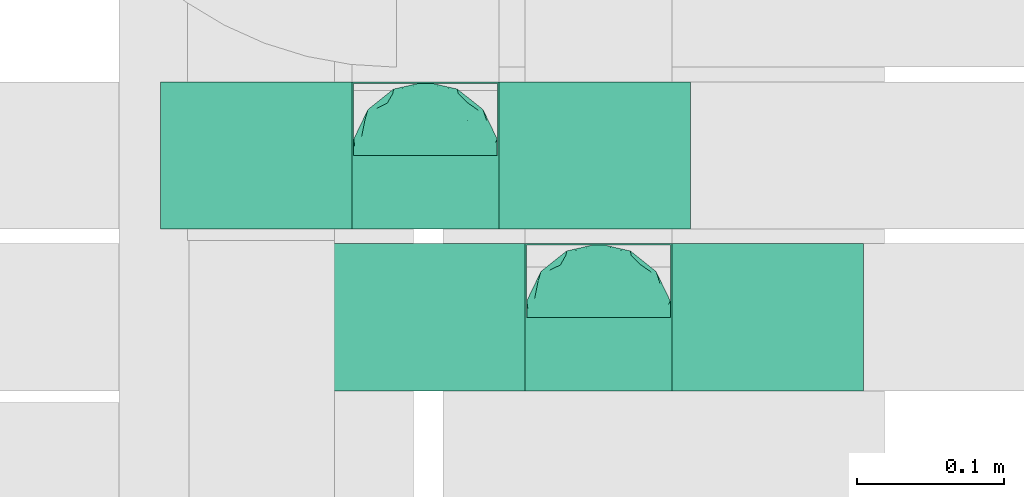
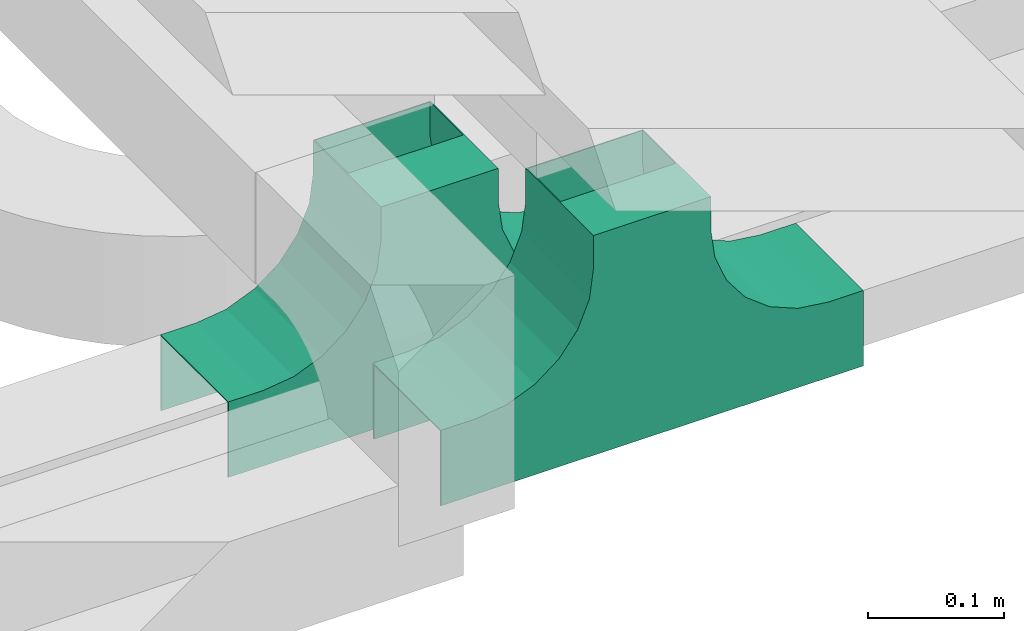
# One storey, part 15 of 19: 2 flow fittings.
"""IFC2X3 building model written with IfcOpenShell, lengths in millimetres."""

from ifc_helpers import new_model, entity, si_unit, converted_unit, derived_unit, direction, frame, origin, place, context, subcontext, project, spatial, faceted_brep, source, transform, mapped, material, material_list, type_object, type_shapes, element, save


model = new_model("IFC2X3")

# Units and contexts
model_context = context("Model", 3, precision=0.01, world=origin(), true_north=direction((6.12303176911189e-17, 1.0)))
body_context = subcontext(model_context, "Body", "Model", "MODEL_VIEW")
ifc_project = project(units=[si_unit("LENGTHUNIT", "METRE", prefix="MILLI"), si_unit("AREAUNIT", "SQUARE_METRE"), si_unit("VOLUMEUNIT", "CUBIC_METRE"), converted_unit("PLANEANGLEUNIT", "DEGREE", entity("IfcRatioMeasure", 0.0174532925199433), si_unit("PLANEANGLEUNIT", "RADIAN"), dimensions=[0, 0, 0, 0, 0, 0, 0]), si_unit("MASSUNIT", "GRAM", prefix="KILO"), derived_unit("MASSDENSITYUNIT", [(si_unit("MASSUNIT", "GRAM", prefix="KILO"), 1), (si_unit("LENGTHUNIT", "METRE"), -3)]), derived_unit("MOMENTOFINERTIAUNIT", [(si_unit("LENGTHUNIT", "METRE"), 4)]), si_unit("TIMEUNIT", "SECOND"), si_unit("FREQUENCYUNIT", "HERTZ"), si_unit("THERMODYNAMICTEMPERATUREUNIT", "DEGREE_CELSIUS"), derived_unit("THERMALTRANSMITTANCEUNIT", [(si_unit("MASSUNIT", "GRAM", prefix="KILO"), 1), (si_unit("THERMODYNAMICTEMPERATUREUNIT", "KELVIN"), -1), (si_unit("TIMEUNIT", "SECOND"), -3)]), derived_unit("VOLUMETRICFLOWRATEUNIT", [(si_unit("LENGTHUNIT", "METRE"), 3), (si_unit("TIMEUNIT", "SECOND"), -1)]), derived_unit("MASSFLOWRATEUNIT", [(si_unit("MASSUNIT", "GRAM", prefix="KILO"), 1), (si_unit("TIMEUNIT", "SECOND"), -1)]), derived_unit("ROTATIONALFREQUENCYUNIT", [(si_unit("TIMEUNIT", "SECOND"), -1)]), si_unit("ELECTRICCURRENTUNIT", "AMPERE"), si_unit("ELECTRICVOLTAGEUNIT", "VOLT"), si_unit("POWERUNIT", "WATT"), si_unit("FORCEUNIT", "NEWTON", prefix="KILO"), si_unit("ILLUMINANCEUNIT", "LUX"), si_unit("LUMINOUSFLUXUNIT", "LUMEN"), si_unit("LUMINOUSINTENSITYUNIT", "CANDELA"), derived_unit("USERDEFINED", [(si_unit("MASSUNIT", "GRAM", prefix="KILO"), -1), (si_unit("LENGTHUNIT", "METRE"), -2), (si_unit("TIMEUNIT", "SECOND"), 3), (si_unit("LUMINOUSFLUXUNIT", "LUMEN"), 1)]), derived_unit("LINEARVELOCITYUNIT", [(si_unit("LENGTHUNIT", "METRE"), 1), (si_unit("TIMEUNIT", "SECOND"), -1)]), si_unit("PRESSUREUNIT", "PASCAL"), derived_unit("USERDEFINED", [(si_unit("LENGTHUNIT", "METRE"), -2), (si_unit("MASSUNIT", "GRAM", prefix="KILO"), 1), (si_unit("TIMEUNIT", "SECOND"), -2)]), derived_unit("LINEARFORCEUNIT", [(si_unit("MASSUNIT", "GRAM", prefix="KILO"), 1), (si_unit("LENGTHUNIT", "METRE"), 1), (si_unit("TIMEUNIT", "SECOND"), -2), (si_unit("LENGTHUNIT", "METRE"), -1)]), derived_unit("PLANARFORCEUNIT", [(si_unit("MASSUNIT", "GRAM", prefix="KILO"), 1), (si_unit("LENGTHUNIT", "METRE"), 1), (si_unit("TIMEUNIT", "SECOND"), -2), (si_unit("LENGTHUNIT", "METRE"), -2)])], contexts=[model_context])

# Site, building, storey
site_placement = place(None, origin())
site = spatial("IfcSite", under=ifc_project, at=site_placement, CompositionType="ELEMENT")
building_placement = place(site_placement, origin())
building = spatial("IfcBuilding", under=site, at=building_placement, CompositionType="ELEMENT")
storey_placement = place(building_placement, frame((0.0, 0.0, 12000.0)))
storey = spatial("IfcBuildingStorey", under=building, at=storey_placement, CompositionType="ELEMENT", Elevation=12000.0)

# Flow fittings
ifc_material_1 = material()
ifc_material_2 = material()
ifc_material_list = material_list([ifc_material_1, ifc_material_2])
cable_carrier_fitting_type = type_object("IfcCableCarrierFittingType", Name="470_DKC_S5_TSS cover (flat)", PredefinedType="NOTDEFINED", material=ifc_material_1)
shared_shape = source(origin(), body_context, "Body", "Brep", [
    faceted_brep([(43.65, -13.62, 44.78), (44.77, 0.0, 42.74), (48.26, -5.6, 53.19), (16.66, 5.33, 18.16), (11.56, -8.33, 17.07), (2.02, 2.7, 15.11), (-7.81, -35.95, 31.14), (-17.21, -38.27, 37.81), (-11.13, -27.32, 24.63), (37.7, -7.25, 32.97), (10.64, 26.52, 23.97), (19.21, 19.84, 23.32), (10.42, 17.81, 19.46), (48.75, 0.0, 65.0), (48.07, 6.52, 52.87), (-37.46, 12.16, 34.19), (-31.35, 12.15, 27.99), (-38.09, 3.52, 32.8), (48.75, 11.13, 65.0), (9.67, 42.57, 40.61), (17.48, 37.97, 37.57), (8.35, 35.36, 30.65), (36.7, 20.43, 37.88), (28.22, 12.58, 25.69), (28.4, 24.01, 31.57), (37.1, 7.75, 32.39), (30.39, 38.11, 65.0), (34.74, 34.64, 65.0), (32.94, 32.13, 45.44), (26.04, 41.58, 65.0), (-44.77, 0.0, 42.74), (-35.92, -8.72, 31.33), (-42.7, -12.19, 42.01), (5.42, -48.76, 65.0), (0.0, -48.78, 54.04), (7.59, -47.43, 51.12), (34.0, -31.65, 46.49), (40.01, -26.24, 50.49), (30.39, -38.11, 65.0), (-47.55, -8.65, 52.2), (43.92, -21.15, 65.0), (-47.55, 8.68, 52.19), (-43.92, 21.15, 65.0), (-41.56, 23.54, 50.22), (-36.7, 20.43, 37.88), (-42.68, 12.16, 41.97), (-0.04, -44.68, 42.56), (43.35, 13.13, 43.81), (-9.67, -42.82, 41.06), (2.93, -38.3, 33.0), (10.58, -32.36, 28.38), (17.48, -37.97, 37.57), (29.42, -14.29, 27.18), (29.26, 0.0, 24.46), (-34.74, 34.64, 65.0), (-35.59, 30.87, 48.26), (16.27, 46.29, 65.0), (15.4, 45.37, 50.7), (10.85, 47.52, 65.0), (-22.09, 42.26, 49.96), (-16.27, 46.29, 65.0), (-15.4, 45.37, 50.7), (-35.57, -30.88, 48.24), (-34.74, -34.64, 65.0), (-41.54, -23.57, 50.22), (-21.2, -29.91, 31.0), (-22.09, -42.26, 49.96), (-28.59, -35.77, 44.93), (27.97, -26.92, 33.49), (26.56, -36.75, 43.94), (-4.7, -12.82, 16.9), (-3.71, -22.05, 20.28), (0.0, -29.85, 24.89), (-8.78, 23.47, 21.73), (-10.71, 12.15, 17.7), (-19.19, 19.81, 23.29), (19.21, -19.84, 23.32), (10.27, -43.25, 42.12), (-16.27, -46.29, 65.0), (-15.42, -45.43, 50.92), (-10.85, -47.52, 65.0), (-21.69, -45.05, 65.0), (-26.04, -41.58, 65.0), (-30.39, -38.11, 65.0), (-26.91, -11.71, 24.52), (-28.57, -22.53, 30.71), (-14.35, 0.55, 17.11), (20.39, 29.7, 30.33), (25.88, 35.56, 41.22), (-1.9, 38.3, 32.91), (-0.04, 44.68, 42.56), (-9.54, 42.67, 40.74), (-10.12, 33.04, 28.86), (-17.21, 38.27, 37.81), (-28.59, 35.77, 44.93), (-30.39, 38.11, 65.0), (-26.04, 41.58, 65.0), (-21.69, 45.05, 65.0), (0.92, 16.99, 17.99), (0.0, 29.85, 24.89), (-28.43, 23.64, 31.34), (22.08, -42.72, 51.3), (0.0, -50.0, 65.0), (-7.98, 47.29, 50.85), (-10.85, 47.52, 65.0), (-5.42, 48.76, 65.0), (-39.09, -31.17, 65.0), (-36.7, -20.43, 37.88), (-20.05, 29.88, 30.29), (48.75, -11.13, 65.0), (36.7, -20.43, 37.88), (39.09, -31.17, 65.0), (43.92, 21.15, 65.0), (41.04, 24.48, 50.28), (21.43, -9.87, 20.92), (19.85, -30.3, 30.53), (26.04, -41.58, 65.0), (8.28, -22.62, 21.18), (-19.19, -19.81, 23.29), (-17.56, -9.66, 19.19), (-29.26, 0.0, 24.46), (-22.28, 8.45, 21.04), (21.69, -45.05, 65.0), (-7.75, -47.32, 50.85), (22.09, 42.36, 50.25), (21.69, 45.05, 65.0), (7.94, 47.25, 50.71), (5.42, 48.76, 65.0), (-43.92, -21.15, 65.0), (-39.09, 31.17, 65.0), (-48.75, 11.13, 65.0), (-48.75, -11.13, 65.0), (-48.75, 0.0, 65.0), (0.0, 50.0, 65.0), (0.0, 48.77, 53.96), (-5.42, -48.76, 65.0), (16.27, -46.29, 65.0), (10.85, -47.52, 65.0), (39.09, 31.17, 65.0), (34.74, -34.64, 65.0), (-43.65, -13.62, 85.22), (-44.77, 0.0, 87.26), (-48.26, -5.6, 76.81), (-16.66, 5.33, 111.84), (-11.56, -8.33, 112.93), (-2.02, 2.7, 114.89), (7.81, -35.95, 98.86), (17.21, -38.27, 92.19), (11.13, -27.32, 105.37), (-37.7, -7.25, 97.03), (-10.64, 26.52, 106.03), (-19.21, 19.84, 106.68), (-10.42, 17.81, 110.54), (-48.07, 6.52, 77.13), (37.46, 12.16, 95.81), (31.35, 12.15, 102.01), (38.09, 3.52, 97.2), (-9.67, 42.57, 89.39), (-17.48, 37.97, 92.43), (-8.35, 35.36, 99.35), (-36.7, 20.43, 92.12), (-28.22, 12.58, 104.31), (-28.4, 24.01, 98.43), (-37.1, 7.75, 97.61), (-32.94, 32.13, 84.56), (44.77, 0.0, 87.26), (35.92, -8.72, 98.67), (42.7, -12.19, 87.99), (0.0, -48.78, 75.96), (-7.59, -47.43, 78.88), (-34.0, -31.65, 83.51), (-40.01, -26.24, 79.51), (47.55, -8.65, 77.8), (47.55, 8.68, 77.81), (41.56, 23.54, 79.78), (36.7, 20.43, 92.12), (42.68, 12.16, 88.03), (0.04, -44.68, 87.44), (-43.35, 13.13, 86.19), (9.67, -42.82, 88.94), (-2.93, -38.3, 97.0), (-10.58, -32.36, 101.62), (-17.48, -37.97, 92.43), (-29.42, -14.29, 102.82), (-29.26, 0.0, 105.54), (35.59, 30.87, 81.74), (-15.4, 45.37, 79.3), (22.09, 42.26, 80.04), (15.4, 45.37, 79.3), (35.57, -30.88, 81.76), (41.54, -23.57, 79.78), (21.2, -29.91, 99.0), (22.09, -42.26, 80.04), (28.59, -35.77, 85.07), (-27.97, -26.92, 96.51), (-26.56, -36.75, 86.06), (4.7, -12.82, 113.1), (3.71, -22.05, 109.72), (0.0, -29.85, 105.11), (8.78, 23.47, 108.27), (10.71, 12.15, 112.3), (19.19, 19.81, 106.71), (-19.21, -19.84, 106.68), (-10.27, -43.25, 87.88), (15.42, -45.43, 79.08), (26.91, -11.71, 105.48), (28.57, -22.53, 99.29), (14.35, 0.55, 112.89), (-20.39, 29.7, 99.67), (-25.88, 35.56, 88.78), (1.9, 38.3, 97.09), (0.04, 44.68, 87.44), (9.54, 42.67, 89.26), (10.12, 33.04, 101.14), (17.21, 38.27, 92.19), (28.59, 35.77, 85.07), (-0.92, 16.99, 112.01), (0.0, 29.85, 105.11), (28.43, 23.64, 98.66), (-22.08, -42.72, 78.7), (7.98, 47.29, 79.15), (36.7, -20.43, 92.12), (20.05, 29.88, 99.71), (-36.7, -20.43, 92.12), (-41.04, 24.48, 79.72), (-21.43, -9.87, 109.08), (-19.85, -30.3, 99.47), (-8.28, -22.62, 108.82), (19.19, -19.81, 106.71), (17.56, -9.66, 110.81), (29.26, 0.0, 105.54), (22.28, 8.45, 108.96), (7.75, -47.32, 79.15), (-22.09, 42.36, 79.75), (-7.94, 47.25, 79.29), (0.0, 48.77, 76.04)], [[[0, 1, 2]], [[3, 4, 5]], [[6, 7, 8]], [[1, 0, 9]], [[10, 11, 12]], [[13, 2, 14]], [[15, 16, 17]], [[14, 18, 13]], [[19, 20, 21]], [[22, 23, 24]], [[1, 9, 25]], [[26, 27, 28, 29]], [[30, 31, 32]], [[33, 34, 35]], [[36, 37, 38]], [[32, 39, 30]], [[2, 40, 0]], [[23, 22, 25]], [[41, 42, 43]], [[44, 15, 45]], [[46, 35, 34]], [[25, 22, 47]], [[31, 30, 17]], [[48, 49, 46]], [[50, 51, 49]], [[52, 53, 9]], [[43, 54, 55]], [[56, 57, 58]], [[59, 60, 61]], [[62, 63, 64]], [[8, 7, 65]], [[7, 66, 67]], [[68, 36, 69]], [[70, 5, 4]], [[8, 71, 72]], [[73, 74, 75]], [[68, 76, 52]], [[77, 46, 49]], [[78, 79, 80]], [[7, 6, 48]], [[67, 81, 82, 83]], [[84, 85, 31]], [[85, 65, 67]], [[70, 86, 5]], [[23, 3, 11]], [[21, 87, 10]], [[21, 20, 87]], [[28, 24, 88]], [[19, 89, 90]], [[91, 90, 89]], [[91, 92, 93]], [[94, 95, 96, 97]], [[98, 99, 10]], [[100, 16, 44]], [[77, 51, 101]], [[33, 102, 34]], [[103, 91, 61]], [[93, 59, 61]], [[104, 105, 103]], [[106, 64, 63]], [[107, 31, 85]], [[100, 94, 108]], [[108, 93, 92]], [[43, 55, 44]], [[0, 40, 37]], [[2, 13, 109]], [[2, 1, 14]], [[110, 9, 0]], [[2, 109, 40]], [[37, 40, 111]], [[47, 14, 1]], [[112, 14, 47]], [[113, 112, 47]], [[112, 18, 14]], [[47, 22, 113]], [[52, 9, 110]], [[53, 25, 9]], [[25, 47, 1]], [[23, 25, 53]], [[68, 52, 110]], [[76, 4, 114]], [[51, 115, 69]], [[50, 115, 51]], [[110, 36, 68]], [[3, 23, 53]], [[23, 11, 24]], [[52, 76, 114]], [[98, 12, 5]], [[11, 87, 24]], [[24, 28, 22]], [[87, 88, 24]], [[36, 116, 69]], [[28, 27, 113]], [[114, 3, 53]], [[76, 115, 117]], [[70, 4, 117]], [[118, 84, 119]], [[119, 70, 118]], [[120, 16, 121]], [[37, 36, 110]], [[116, 36, 38]], [[116, 122, 69]], [[34, 123, 46]], [[10, 87, 11]], [[87, 20, 88]], [[12, 98, 10]], [[10, 99, 21]], [[74, 5, 86]], [[73, 75, 108]], [[124, 56, 125]], [[124, 29, 88]], [[89, 21, 99]], [[21, 89, 19]], [[92, 89, 99]], [[89, 92, 91]], [[126, 127, 58]], [[88, 29, 28]], [[20, 57, 124]], [[88, 20, 124]], [[57, 20, 19]], [[73, 92, 99]], [[92, 73, 108]], [[99, 98, 73]], [[74, 86, 121]], [[73, 98, 74]], [[5, 74, 98]], [[100, 108, 75]], [[94, 93, 108]], [[86, 120, 121]], [[100, 44, 55]], [[75, 16, 100]], [[17, 16, 120]], [[31, 17, 120]], [[17, 30, 45]], [[84, 31, 120]], [[31, 107, 32]], [[41, 45, 30]], [[43, 44, 45]], [[107, 64, 32]], [[39, 64, 128]], [[30, 39, 41]], [[129, 43, 42]], [[41, 130, 42]], [[43, 45, 41]], [[62, 83, 63]], [[95, 94, 55]], [[100, 55, 94]], [[64, 107, 62]], [[131, 39, 128]], [[64, 106, 128]], [[85, 62, 107]], [[67, 83, 62]], [[39, 32, 64]], [[130, 41, 132]], [[59, 97, 60]], [[133, 127, 134]], [[59, 94, 97]], [[104, 61, 60]], [[94, 59, 93]], [[126, 134, 127]], [[126, 58, 57]], [[19, 90, 126]], [[134, 105, 133]], [[126, 90, 134]], [[103, 90, 91]], [[105, 134, 103]], [[90, 103, 134]], [[119, 120, 86]], [[84, 118, 85]], [[65, 85, 118]], [[62, 85, 67]], [[8, 65, 118]], [[67, 65, 7]], [[71, 118, 70]], [[8, 72, 6]], [[49, 6, 72]], [[6, 49, 48]], [[50, 49, 72]], [[77, 49, 51]], [[101, 69, 122]], [[123, 34, 135]], [[101, 122, 136]], [[137, 77, 136]], [[78, 81, 66]], [[7, 79, 66]], [[67, 66, 81]], [[79, 7, 48]], [[35, 137, 33]], [[123, 80, 79]], [[135, 34, 102]], [[35, 46, 77]], [[80, 123, 135]], [[46, 123, 48]], [[117, 50, 72]], [[115, 76, 68]], [[117, 72, 71]], [[4, 76, 117]], [[39, 132, 41]], [[39, 131, 132]], [[137, 35, 77]], [[124, 57, 56]], [[126, 57, 19]], [[103, 61, 104]], [[61, 91, 93]], [[77, 101, 136]], [[51, 69, 101]], [[28, 113, 22]], [[112, 113, 138]], [[16, 75, 121]], [[74, 121, 75]], [[66, 79, 78]], [[123, 79, 48]], [[0, 37, 110]], [[37, 111, 139, 38]], [[29, 124, 125]], [[115, 50, 117]], [[69, 115, 68]], [[120, 119, 84]], [[70, 119, 86]], [[11, 3, 12]], [[5, 12, 3]], [[118, 71, 8]], [[117, 71, 70]], [[3, 114, 4]], [[53, 52, 114]], [[27, 138, 113]], [[45, 15, 17]], [[44, 16, 15]], [[55, 54, 95]], [[43, 129, 54]], [[140, 141, 142]], [[143, 144, 145]], [[146, 147, 148]], [[141, 140, 149]], [[150, 151, 152]], [[132, 142, 153]], [[154, 155, 156]], [[153, 130, 132]], [[157, 158, 159]], [[160, 161, 162]], [[141, 149, 163]], [[95, 54, 164, 96]], [[165, 166, 167]], [[135, 168, 169]], [[170, 171, 83]], [[167, 172, 165]], [[142, 141, 153]], [[161, 160, 163]], [[173, 112, 174]], [[175, 154, 176]], [[177, 169, 168]], [[163, 160, 178]], [[166, 165, 156]], [[179, 180, 177]], [[181, 182, 180]], [[183, 184, 149]], [[174, 27, 185]], [[60, 186, 104]], [[187, 56, 188]], [[189, 139, 190]], [[148, 147, 191]], [[147, 192, 193]], [[194, 170, 195]], [[196, 145, 144]], [[148, 197, 198]], [[199, 200, 201]], [[194, 202, 183]], [[203, 177, 180]], [[136, 204, 137]], [[147, 146, 179]], [[193, 122, 116, 38]], [[205, 206, 166]], [[206, 191, 193]], [[196, 207, 145]], [[161, 143, 151]], [[159, 208, 150]], [[159, 158, 208]], [[164, 162, 209]], [[157, 210, 211]], [[212, 211, 210]], [[212, 213, 214]], [[215, 26, 29, 125]], [[216, 217, 150]], [[218, 155, 175]], [[203, 182, 219]], [[135, 102, 168]], [[220, 212, 188]], [[214, 187, 188]], [[58, 127, 220]], [[111, 190, 139]], [[221, 166, 206]], [[218, 215, 222]], [[222, 214, 213]], [[174, 185, 175]], [[171, 140, 128]], [[132, 131, 142]], [[142, 128, 140]], [[223, 149, 140]], [[142, 131, 128]], [[171, 128, 106]], [[178, 153, 141]], [[42, 153, 178]], [[224, 42, 178]], [[42, 130, 153]], [[178, 160, 224]], [[183, 149, 223]], [[184, 163, 149]], [[163, 178, 141]], [[161, 163, 184]], [[194, 183, 223]], [[202, 144, 225]], [[182, 226, 195]], [[181, 226, 182]], [[223, 170, 194]], [[143, 161, 184]], [[161, 151, 162]], [[183, 202, 225]], [[216, 152, 145]], [[151, 208, 162]], [[162, 164, 160]], [[208, 209, 162]], [[170, 82, 195]], [[164, 54, 224]], [[225, 143, 184]], [[202, 226, 227]], [[196, 144, 227]], [[228, 205, 229]], [[229, 196, 228]], [[230, 155, 231]], [[171, 170, 223]], [[82, 170, 83]], [[82, 81, 195]], [[168, 232, 177]], [[150, 208, 151]], [[208, 158, 209]], [[152, 216, 150]], [[150, 217, 159]], [[200, 145, 207]], [[199, 201, 222]], [[233, 60, 97]], [[233, 96, 209]], [[210, 159, 217]], [[159, 210, 157]], [[213, 210, 217]], [[210, 213, 212]], [[234, 105, 104]], [[209, 96, 164]], [[158, 186, 233]], [[209, 158, 233]], [[186, 158, 157]], [[199, 213, 217]], [[213, 199, 222]], [[217, 216, 199]], [[200, 207, 231]], [[199, 216, 200]], [[145, 200, 216]], [[218, 222, 201]], [[215, 214, 222]], [[207, 230, 231]], [[218, 175, 185]], [[201, 155, 218]], [[156, 155, 230]], [[166, 156, 230]], [[156, 165, 176]], [[205, 166, 230]], [[166, 221, 167]], [[173, 176, 165]], [[174, 175, 176]], [[221, 190, 167]], [[172, 190, 40]], [[165, 172, 173]], [[138, 174, 112]], [[173, 18, 112]], [[174, 176, 173]], [[189, 38, 139]], [[26, 215, 185]], [[218, 185, 215]], [[190, 221, 189]], [[109, 172, 40]], [[190, 111, 40]], [[206, 189, 221]], [[193, 38, 189]], [[172, 167, 190]], [[18, 173, 13]], [[187, 125, 56]], [[133, 105, 235]], [[187, 215, 125]], [[58, 188, 56]], [[215, 187, 214]], [[234, 235, 105]], [[234, 104, 186]], [[157, 211, 234]], [[235, 127, 133]], [[234, 211, 235]], [[220, 211, 212]], [[127, 235, 220]], [[211, 220, 235]], [[229, 230, 207]], [[205, 228, 206]], [[191, 206, 228]], [[189, 206, 193]], [[148, 191, 228]], [[193, 191, 147]], [[197, 228, 196]], [[148, 198, 146]], [[180, 146, 198]], [[146, 180, 179]], [[181, 180, 198]], [[203, 180, 182]], [[219, 195, 81]], [[232, 168, 33]], [[219, 81, 78]], [[80, 203, 78]], [[136, 122, 192]], [[147, 204, 192]], [[193, 192, 122]], [[204, 147, 179]], [[169, 80, 135]], [[232, 137, 204]], [[33, 168, 102]], [[169, 177, 203]], [[137, 232, 33]], [[177, 232, 179]], [[227, 181, 198]], [[226, 202, 194]], [[227, 198, 197]], [[144, 202, 227]], [[172, 13, 173]], [[172, 109, 13]], [[80, 169, 203]], [[233, 186, 60]], [[234, 186, 157]], [[220, 188, 58]], [[188, 212, 214]], [[203, 219, 78]], [[182, 195, 219]], [[164, 224, 160]], [[42, 224, 129]], [[155, 201, 231]], [[200, 231, 201]], [[192, 204, 136]], [[232, 204, 179]], [[140, 171, 223]], [[171, 106, 63, 83]], [[96, 233, 97]], [[226, 181, 227]], [[195, 226, 194]], [[230, 229, 205]], [[196, 229, 207]], [[151, 143, 152]], [[145, 152, 143]], [[228, 197, 148]], [[227, 197, 196]], [[143, 225, 144]], [[184, 183, 225]], [[54, 129, 224]], [[176, 154, 156]], [[175, 155, 154]], [[185, 27, 26]], [[174, 138, 27]]]),
    faceted_brep([(-50.0, -50.0, 155.0), (50.0, -50.0, 155.0), (50.0, 0.0, 155.0), (-50.0, 0.0, 155.0), (-50.0, -50.0, 154.0), (-50.0, 0.0, 154.0), (50.0, 0.0, 154.0), (50.0, -50.0, 154.0)], [[[0, 1, 2, 3]], [[4, 5, 6, 7]], [[1, 0, 4, 7]], [[2, 1, 7, 6]], [[3, 2, 6, 5]], [[0, 3, 5, 4]]]),
    faceted_brep([(124.12, -50.0, 28.41), (100.0, -50.0, 38.4), (79.29, -50.0, 54.29), (63.4, -50.0, 75.0), (53.41, -50.0, 99.12), (50.0, -50.0, 125.0), (50.0, -50.0, 155.0), (49.0, -50.0, 155.0), (49.0, -50.0, 125.0), (52.44, -50.0, 98.86), (62.53, -50.0, 74.5), (78.58, -50.0, 53.58), (99.5, -50.0, 37.53), (123.86, -50.0, 27.44), (150.0, -50.0, 24.0), (180.0, -50.0, 24.0), (180.0, -50.0, 25.0), (150.0, -50.0, 25.0), (49.0, 50.0, 125.0), (49.0, 50.0, 155.0), (50.0, 50.0, 155.0), (50.0, 50.0, 125.0), (53.41, 50.0, 99.12), (63.4, 50.0, 75.0), (79.29, 50.0, 54.29), (100.0, 50.0, 38.4), (124.12, 50.0, 28.41), (150.0, 50.0, 25.0), (180.0, 50.0, 25.0), (180.0, 50.0, 24.0), (150.0, 50.0, 24.0), (123.86, 50.0, 27.44), (99.5, 50.0, 37.53), (78.58, 50.0, 53.58), (62.53, 50.0, 74.5), (52.44, 50.0, 98.86)], [[[0, 1, 2, 3, 4, 5, 6, 7, 8, 9, 10, 11, 12, 13, 14, 15, 16, 17]], [[18, 19, 20, 21, 22, 23, 24, 25, 26, 27, 28, 29, 30, 31, 32, 33, 34, 35]], [[7, 6, 20, 19]], [[8, 7, 19, 18]], [[9, 35, 34, 10]], [[10, 34, 33, 11]], [[18, 35, 9, 8]], [[12, 32, 31, 13]], [[13, 31, 30, 14]], [[11, 33, 32, 12]], [[15, 14, 30, 29]], [[16, 15, 29, 28]], [[17, 16, 28, 27]], [[0, 17, 27, 26]], [[1, 0, 26, 25]], [[25, 24, 2, 1]], [[4, 3, 23, 22]], [[5, 4, 22, 21]], [[24, 23, 3, 2]], [[6, 5, 21, 20]]]),
    faceted_brep([(-53.41, -50.0, 99.12), (-63.4, -50.0, 75.0), (-79.29, -50.0, 54.29), (-100.0, -50.0, 38.4), (-124.12, -50.0, 28.41), (-150.0, -50.0, 25.0), (-180.0, -50.0, 25.0), (-180.0, -50.0, 24.0), (-150.0, -50.0, 24.0), (-123.86, -50.0, 27.44), (-99.5, -50.0, 37.53), (-78.58, -50.0, 53.58), (-62.53, -50.0, 74.5), (-52.44, -50.0, 98.86), (-49.0, -50.0, 125.0), (-49.0, -50.0, 155.0), (-50.0, -50.0, 155.0), (-50.0, -50.0, 125.0), (-150.0, 50.0, 24.0), (-180.0, 50.0, 24.0), (-180.0, 50.0, 25.0), (-150.0, 50.0, 25.0), (-124.12, 50.0, 28.41), (-100.0, 50.0, 38.4), (-79.29, 50.0, 54.29), (-63.4, 50.0, 75.0), (-53.41, 50.0, 99.12), (-50.0, 50.0, 125.0), (-50.0, 50.0, 155.0), (-49.0, 50.0, 155.0), (-49.0, 50.0, 125.0), (-52.44, 50.0, 98.86), (-62.53, 50.0, 74.5), (-78.58, 50.0, 53.58), (-99.5, 50.0, 37.53), (-123.86, 50.0, 27.44)], [[[0, 1, 2, 3, 4, 5, 6, 7, 8, 9, 10, 11, 12, 13, 14, 15, 16, 17]], [[18, 19, 20, 21, 22, 23, 24, 25, 26, 27, 28, 29, 30, 31, 32, 33, 34, 35]], [[17, 16, 28, 27]], [[0, 17, 27, 26]], [[1, 0, 26, 25]], [[25, 24, 2, 1]], [[4, 3, 23, 22]], [[5, 4, 22, 21]], [[24, 23, 3, 2]], [[6, 5, 21, 20]], [[7, 6, 20, 19]], [[8, 7, 19, 18]], [[9, 35, 34, 10]], [[10, 34, 33, 11]], [[18, 35, 9, 8]], [[12, 32, 31, 13]], [[13, 31, 30, 14]], [[11, 33, 32, 12]], [[15, 14, 30, 29]], [[16, 15, 29, 28]]]),
    faceted_brep([(-50.0, -50.0, 155.0), (-50.0, -50.0, 125.0), (-50.71, -50.0, 119.61), (-51.42, -50.0, 114.21), (-51.92, -50.0, 110.44), (-52.41, -50.0, 106.67), (-52.91, -50.0, 102.89), (-53.41, -50.0, 99.12), (-55.9, -50.0, 93.09), (-58.4, -50.0, 87.06), (-60.9, -50.0, 81.03), (-63.4, -50.0, 75.0), (-67.37, -50.0, 69.82), (-71.34, -50.0, 64.64), (-75.32, -50.0, 59.47), (-79.29, -50.0, 54.29), (-84.47, -50.0, 50.32), (-89.64, -50.0, 46.34), (-94.82, -50.0, 42.37), (-100.0, -50.0, 38.4), (-106.03, -50.0, 35.9), (-112.06, -50.0, 33.4), (-118.09, -50.0, 30.9), (-124.12, -50.0, 28.41), (-130.59, -50.0, 27.56), (-137.06, -50.0, 26.7), (-143.53, -50.0, 25.85), (-150.0, -50.0, 25.0), (-180.0, -50.0, 25.0), (-180.0, -50.0, -43.0), (180.0, -50.0, -43.0), (180.0, -50.0, 25.0), (150.0, -50.0, 25.0), (144.61, -50.0, 25.71), (139.21, -50.0, 26.42), (135.44, -50.0, 26.92), (131.67, -50.0, 27.41), (127.89, -50.0, 27.91), (124.12, -50.0, 28.41), (118.09, -50.0, 30.9), (112.06, -50.0, 33.4), (106.03, -50.0, 35.9), (100.0, -50.0, 38.4), (94.82, -50.0, 42.37), (89.64, -50.0, 46.34), (84.47, -50.0, 50.32), (79.29, -50.0, 54.29), (75.32, -50.0, 59.47), (71.34, -50.0, 64.64), (67.37, -50.0, 69.82), (63.4, -50.0, 75.0), (60.9, -50.0, 81.03), (58.4, -50.0, 87.06), (55.9, -50.0, 93.09), (53.41, -50.0, 99.12), (52.56, -50.0, 105.59), (51.7, -50.0, 112.06), (50.85, -50.0, 118.53), (50.0, -50.0, 125.0), (50.0, -50.0, 155.0), (-180.0, -49.0, -43.0), (-180.0, -49.0, 25.0), (-150.0, -49.0, 25.0), (-144.61, -49.0, 25.71), (-139.21, -49.0, 26.42), (-135.44, -49.0, 26.92), (-131.67, -49.0, 27.41), (-127.89, -49.0, 27.91), (-124.12, -49.0, 28.41), (-118.09, -49.0, 30.9), (-112.06, -49.0, 33.4), (-106.03, -49.0, 35.9), (-100.0, -49.0, 38.4), (-94.82, -49.0, 42.37), (-89.64, -49.0, 46.34), (-84.47, -49.0, 50.32), (-79.29, -49.0, 54.29), (-75.32, -49.0, 59.47), (-71.34, -49.0, 64.64), (-67.37, -49.0, 69.82), (-63.4, -49.0, 75.0), (-60.9, -49.0, 81.03), (-58.4, -49.0, 87.06), (-55.9, -49.0, 93.09), (-53.41, -49.0, 99.12), (-52.56, -49.0, 105.59), (-51.7, -49.0, 112.06), (-50.85, -49.0, 118.53), (-50.0, -49.0, 125.0), (-50.0, -49.0, 155.0), (50.0, -49.0, 155.0), (50.0, -49.0, 125.0), (50.71, -49.0, 119.61), (51.21, -49.0, 115.83), (51.7, -49.0, 112.06), (52.56, -49.0, 105.59), (53.41, -49.0, 99.12), (55.9, -49.0, 93.09), (58.4, -49.0, 87.06), (60.9, -49.0, 81.03), (63.4, -49.0, 75.0), (67.37, -49.0, 69.82), (71.34, -49.0, 64.64), (75.32, -49.0, 59.47), (79.29, -49.0, 54.29), (84.47, -49.0, 50.32), (89.64, -49.0, 46.34), (94.82, -49.0, 42.37), (100.0, -49.0, 38.4), (106.03, -49.0, 35.9), (112.06, -49.0, 33.4), (118.09, -49.0, 30.9), (124.12, -49.0, 28.41), (130.59, -49.0, 27.56), (137.06, -49.0, 26.7), (143.53, -49.0, 25.85), (150.0, -49.0, 25.0), (180.0, -49.0, 25.0), (180.0, -49.0, -43.0)], [[[0, 1, 2, 3, 4, 5, 6, 7, 8, 9, 10, 11, 12, 13, 14, 15, 16, 17, 18, 19, 20, 21, 22, 23, 24, 25, 26, 27, 28, 29, 30, 31, 32, 33, 34, 35, 36, 37, 38, 39, 40, 41, 42, 43, 44, 45, 46, 47, 48, 49, 50, 51, 52, 53, 54, 55, 56, 57, 58, 59]], [[60, 61, 62, 63, 64, 65, 66, 67, 68, 69, 70, 71, 72, 73, 74, 75, 76, 77, 78, 79, 80, 81, 82, 83, 84, 85, 86, 87, 88, 89, 90, 91, 92, 93, 94, 95, 96, 97, 98, 99, 100, 101, 102, 103, 104, 105, 106, 107, 108, 109, 110, 111, 112, 113, 114, 115, 116, 117, 118]], [[1, 0, 89, 88]], [[85, 84, 7, 6, 5, 4, 3, 2, 1, 88, 87, 86]], [[69, 68, 23, 22, 21, 20, 19, 72, 71, 70]], [[76, 15, 14, 13, 12, 11, 80, 79, 78, 77]], [[10, 9, 8, 7, 84, 83, 82, 81, 80, 11]], [[62, 27, 26, 25, 24, 23, 68, 67, 66, 65, 64, 63]], [[15, 76, 75, 74, 73, 72, 19, 18, 17, 16]], [[28, 27, 62, 61]], [[32, 31, 117, 116]], [[29, 28, 61, 60]], [[30, 29, 60, 118]], [[31, 30, 118, 117]], [[113, 112, 38, 37, 36, 35, 34, 33, 32, 116, 115, 114]], [[92, 91, 58, 57, 56, 55, 54, 96, 95, 94, 93]], [[104, 46, 45, 44, 43, 42, 108, 107, 106, 105]], [[108, 42, 41, 40, 39, 38, 112, 111, 110, 109]], [[96, 54, 53, 52, 51, 50, 100, 99, 98, 97]], [[46, 104, 103, 102, 101, 100, 50, 49, 48, 47]], [[59, 58, 91, 90]], [[0, 59, 90, 89]]]),
    faceted_brep([(-79.29, 49.0, 54.29), (-84.47, 49.0, 50.32), (-89.64, 49.0, 46.34), (-94.82, 49.0, 42.37), (-100.0, 49.0, 38.4), (-106.03, 49.0, 35.9), (-112.06, 49.0, 33.4), (-118.09, 49.0, 30.9), (-124.12, 49.0, 28.41), (-130.59, 49.0, 27.56), (-137.06, 49.0, 26.7), (-143.53, 49.0, 25.85), (-150.0, 49.0, 25.0), (-180.0, 49.0, 25.0), (-180.0, 49.0, -43.0), (180.0, 49.0, -43.0), (180.0, 49.0, 25.0), (150.0, 49.0, 25.0), (144.61, 49.0, 25.71), (139.21, 49.0, 26.42), (135.44, 49.0, 26.92), (131.67, 49.0, 27.41), (127.89, 49.0, 27.91), (124.12, 49.0, 28.41), (118.09, 49.0, 30.9), (112.06, 49.0, 33.4), (106.03, 49.0, 35.9), (100.0, 49.0, 38.4), (94.82, 49.0, 42.37), (89.64, 49.0, 46.34), (84.47, 49.0, 50.32), (79.29, 49.0, 54.29), (75.32, 49.0, 59.47), (71.34, 49.0, 64.64), (67.37, 49.0, 69.82), (63.4, 49.0, 75.0), (60.9, 49.0, 81.03), (58.4, 49.0, 87.06), (55.9, 49.0, 93.09), (53.41, 49.0, 99.12), (52.56, 49.0, 105.59), (51.7, 49.0, 112.06), (50.85, 49.0, 118.53), (50.0, 49.0, 125.0), (50.0, 49.0, 155.0), (-50.0, 49.0, 155.0), (-50.0, 49.0, 125.0), (-50.71, 49.0, 119.61), (-51.42, 49.0, 114.21), (-51.92, 49.0, 110.44), (-52.41, 49.0, 106.67), (-52.91, 49.0, 102.89), (-53.41, 49.0, 99.12), (-55.9, 49.0, 93.09), (-58.4, 49.0, 87.06), (-60.9, 49.0, 81.03), (-63.4, 49.0, 75.0), (-67.37, 49.0, 69.82), (-71.34, 49.0, 64.64), (-75.32, 49.0, 59.47), (79.29, 50.0, 54.29), (84.47, 50.0, 50.32), (89.64, 50.0, 46.34), (94.82, 50.0, 42.37), (100.0, 50.0, 38.4), (106.03, 50.0, 35.9), (112.06, 50.0, 33.4), (118.09, 50.0, 30.9), (124.12, 50.0, 28.41), (130.59, 50.0, 27.56), (137.06, 50.0, 26.7), (143.53, 50.0, 25.85), (150.0, 50.0, 25.0), (180.0, 50.0, 25.0), (180.0, 50.0, -43.0), (-180.0, 50.0, -43.0), (-180.0, 50.0, 25.0), (-150.0, 50.0, 25.0), (-144.61, 50.0, 25.71), (-139.21, 50.0, 26.42), (-135.44, 50.0, 26.92), (-131.67, 50.0, 27.41), (-127.89, 50.0, 27.91), (-124.12, 50.0, 28.41), (-118.09, 50.0, 30.9), (-112.06, 50.0, 33.4), (-106.03, 50.0, 35.9), (-100.0, 50.0, 38.4), (-94.82, 50.0, 42.37), (-89.64, 50.0, 46.34), (-84.47, 50.0, 50.32), (-79.29, 50.0, 54.29), (-75.32, 50.0, 59.47), (-71.34, 50.0, 64.64), (-67.37, 50.0, 69.82), (-63.4, 50.0, 75.0), (-60.9, 50.0, 81.03), (-58.4, 50.0, 87.06), (-55.9, 50.0, 93.09), (-53.41, 50.0, 99.12), (-52.56, 50.0, 105.59), (-51.7, 50.0, 112.06), (-50.85, 50.0, 118.53), (-50.0, 50.0, 125.0), (-50.0, 50.0, 155.0), (50.0, 50.0, 155.0), (50.0, 50.0, 125.0), (50.71, 50.0, 119.61), (51.21, 50.0, 115.83), (51.7, 50.0, 112.06), (52.56, 50.0, 105.59), (53.41, 50.0, 99.12), (55.9, 50.0, 93.09), (58.4, 50.0, 87.06), (60.9, 50.0, 81.03), (63.4, 50.0, 75.0), (67.37, 50.0, 69.82), (71.34, 50.0, 64.64), (75.32, 50.0, 59.47)], [[[0, 1, 2, 3, 4, 5, 6, 7, 8, 9, 10, 11, 12, 13, 14, 15, 16, 17, 18, 19, 20, 21, 22, 23, 24, 25, 26, 27, 28, 29, 30, 31, 32, 33, 34, 35, 36, 37, 38, 39, 40, 41, 42, 43, 44, 45, 46, 47, 48, 49, 50, 51, 52, 53, 54, 55, 56, 57, 58, 59]], [[60, 61, 62, 63, 64, 65, 66, 67, 68, 69, 70, 71, 72, 73, 74, 75, 76, 77, 78, 79, 80, 81, 82, 83, 84, 85, 86, 87, 88, 89, 90, 91, 92, 93, 94, 95, 96, 97, 98, 99, 100, 101, 102, 103, 104, 105, 106, 107, 108, 109, 110, 111, 112, 113, 114, 115, 116, 117, 118]], [[13, 12, 77, 76]], [[17, 16, 73, 72]], [[14, 13, 76, 75]], [[15, 14, 75, 74]], [[16, 15, 74, 73]], [[69, 68, 23, 22, 21, 20, 19, 18, 17, 72, 71, 70]], [[107, 106, 43, 42, 41, 40, 39, 111, 110, 109, 108]], [[60, 31, 30, 29, 28, 27, 64, 63, 62, 61]], [[64, 27, 26, 25, 24, 23, 68, 67, 66, 65]], [[111, 39, 38, 37, 36, 35, 115, 114, 113, 112]], [[31, 60, 118, 117, 116, 115, 35, 34, 33, 32]], [[44, 43, 106, 105]], [[45, 44, 105, 104]], [[46, 45, 104, 103]], [[100, 99, 52, 51, 50, 49, 48, 47, 46, 103, 102, 101]], [[84, 83, 8, 7, 6, 5, 4, 87, 86, 85]], [[91, 0, 59, 58, 57, 56, 95, 94, 93, 92]], [[55, 54, 53, 52, 99, 98, 97, 96, 95, 56]], [[77, 12, 11, 10, 9, 8, 83, 82, 81, 80, 79, 78]], [[0, 91, 90, 89, 88, 87, 4, 3, 2, 1]]]),
])
type_shapes(cable_carrier_fitting_type, [shared_shape])
for number, where, name in (
    (1, (60300.78, 9784.99, 2525.0), "470_DKC_S5_cover (flat)"),
    (2, (60418.35, 9674.99, 2525.0), "470_DKC_S5_cover (flat)"),
):
    element("IfcFlowFitting", number, at=place(storey_placement, frame(where)), inside=storey, type_object=cable_carrier_fitting_type, material=ifc_material_list, Name=name, ObjectType="470_DKC_S5_TSS cover (flat)", context=body_context, shape_type="MappedRepresentation", body=[
        mapped(shared_shape, transform((0.0, 0.0, 0.0), scale=1.0)),
    ])

save(model, "model.ifc")
